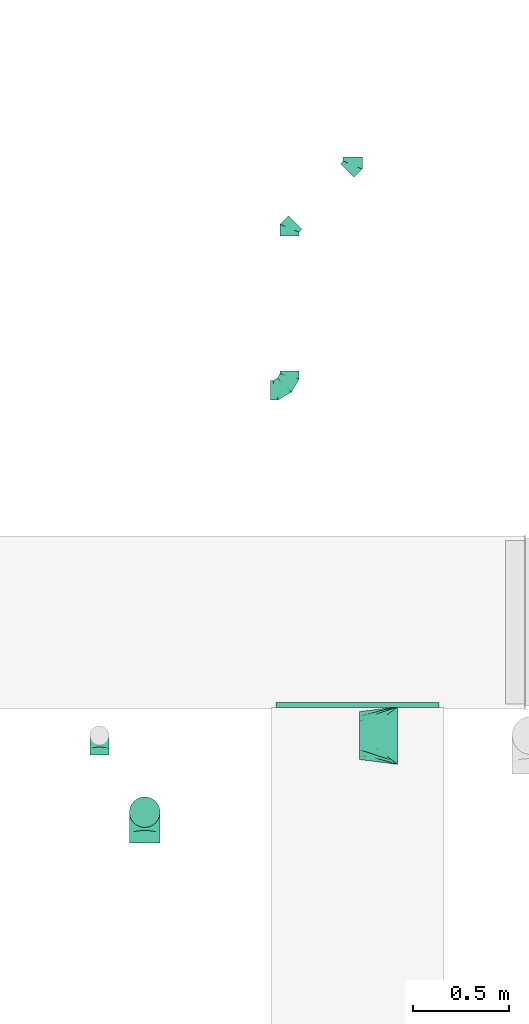
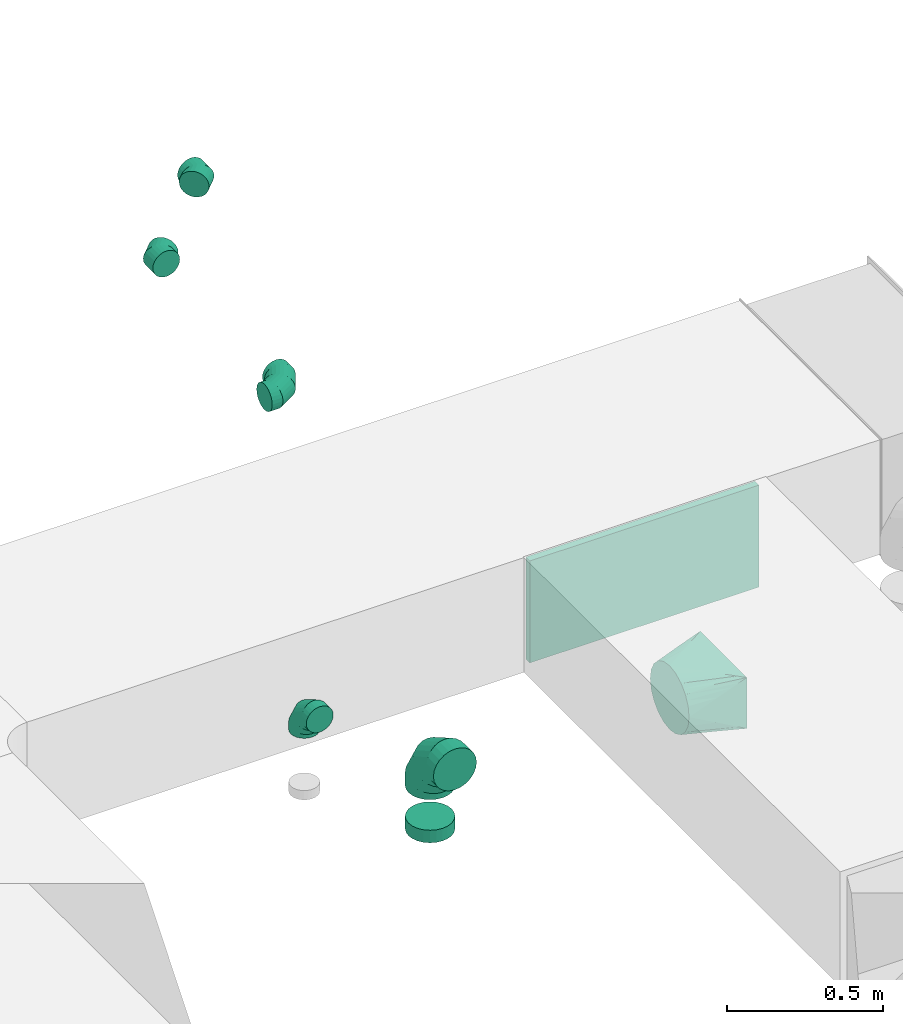
# One storey, part 23 of 62: 8 flow fittings.
"""IFC2X3 building model written with IfcOpenShell, lengths in millimetres."""

from ifc_helpers import new_model, entity, si_unit, converted_unit, derived_unit, direction, frame, origin, origin_2d_with_axis, place, context, subcontext, project, spatial, rectangle, extrude, faceted_brep, source, transform, mapped, material, type_object, type_shapes, element, save


model = new_model("IFC2X3")

# Units and contexts
model_context = context("Model", 3, precision=0.01, world=origin(), true_north=direction((6.12303176911189e-17, 1.0)))
body_context = subcontext(model_context, "Body", "Model", "MODEL_VIEW")
ifc_project = project(units=[si_unit("LENGTHUNIT", "METRE", prefix="MILLI"), si_unit("AREAUNIT", "SQUARE_METRE"), si_unit("VOLUMEUNIT", "CUBIC_METRE"), converted_unit("PLANEANGLEUNIT", "DEGREE", entity("IfcRatioMeasure", 0.0174532925199433), si_unit("PLANEANGLEUNIT", "RADIAN"), dimensions=[0, 0, 0, 0, 0, 0, 0]), si_unit("MASSUNIT", "GRAM", prefix="KILO"), derived_unit("MASSDENSITYUNIT", [(si_unit("MASSUNIT", "GRAM", prefix="KILO"), 1), (si_unit("LENGTHUNIT", "METRE"), -3)]), derived_unit("MOMENTOFINERTIAUNIT", [(si_unit("LENGTHUNIT", "METRE"), 4)]), si_unit("TIMEUNIT", "SECOND"), si_unit("FREQUENCYUNIT", "HERTZ"), si_unit("THERMODYNAMICTEMPERATUREUNIT", "DEGREE_CELSIUS"), derived_unit("THERMALTRANSMITTANCEUNIT", [(si_unit("MASSUNIT", "GRAM", prefix="KILO"), 1), (si_unit("THERMODYNAMICTEMPERATUREUNIT", "KELVIN"), -1), (si_unit("TIMEUNIT", "SECOND"), -3)]), derived_unit("VOLUMETRICFLOWRATEUNIT", [(si_unit("LENGTHUNIT", "METRE"), 3), (si_unit("TIMEUNIT", "SECOND"), -1)]), derived_unit("MASSFLOWRATEUNIT", [(si_unit("MASSUNIT", "GRAM", prefix="KILO"), 1), (si_unit("TIMEUNIT", "SECOND"), -1)]), derived_unit("ROTATIONALFREQUENCYUNIT", [(si_unit("TIMEUNIT", "SECOND"), -1)]), si_unit("ELECTRICCURRENTUNIT", "AMPERE"), si_unit("ELECTRICVOLTAGEUNIT", "VOLT"), si_unit("POWERUNIT", "WATT"), si_unit("FORCEUNIT", "NEWTON", prefix="KILO"), si_unit("ILLUMINANCEUNIT", "LUX"), si_unit("LUMINOUSFLUXUNIT", "LUMEN"), si_unit("LUMINOUSINTENSITYUNIT", "CANDELA"), derived_unit("USERDEFINED", [(si_unit("MASSUNIT", "GRAM", prefix="KILO"), -1), (si_unit("LENGTHUNIT", "METRE"), -2), (si_unit("TIMEUNIT", "SECOND"), 3), (si_unit("LUMINOUSFLUXUNIT", "LUMEN"), 1)]), derived_unit("LINEARVELOCITYUNIT", [(si_unit("LENGTHUNIT", "METRE"), 1), (si_unit("TIMEUNIT", "SECOND"), -1)]), si_unit("PRESSUREUNIT", "PASCAL"), derived_unit("USERDEFINED", [(si_unit("LENGTHUNIT", "METRE"), -2), (si_unit("MASSUNIT", "GRAM", prefix="KILO"), 1), (si_unit("TIMEUNIT", "SECOND"), -2)]), derived_unit("LINEARFORCEUNIT", [(si_unit("MASSUNIT", "GRAM", prefix="KILO"), 1), (si_unit("LENGTHUNIT", "METRE"), 1), (si_unit("TIMEUNIT", "SECOND"), -2), (si_unit("LENGTHUNIT", "METRE"), -1)]), derived_unit("PLANARFORCEUNIT", [(si_unit("MASSUNIT", "GRAM", prefix="KILO"), 1), (si_unit("LENGTHUNIT", "METRE"), 1), (si_unit("TIMEUNIT", "SECOND"), -2), (si_unit("LENGTHUNIT", "METRE"), -2)])], contexts=[model_context])

# Site, building, storey
site_placement = place(None, origin())
site = spatial("IfcSite", under=ifc_project, at=site_placement, CompositionType="ELEMENT")
building_placement = place(site_placement, origin())
building = spatial("IfcBuilding", under=site, at=building_placement, CompositionType="ELEMENT")
storey_placement = place(building_placement, frame((0.0, 0.0, 24000.0)))
storey = spatial("IfcBuildingStorey", under=building, at=storey_placement, CompositionType="ELEMENT", Elevation=24000.0)

# Flow fittings
ifc_material = material()
duct_fitting_type_1 = type_object("IfcDuctFittingType", PredefinedType="NOTDEFINED", material=ifc_material)
shared_shape_1 = source(origin(), body_context, "Body", "SweptSolid", [
    extrude(rectangle(XDim=26.0960000000013, YDim=850.0, at=origin_2d_with_axis()), frame((6.95, 0.0, -200.0)), (0.0, 0.0, 1.0), 400.0),
])
type_shapes(duct_fitting_type_1, [shared_shape_1])
flow_fitting_1_placement = place(storey_placement, frame((30224.65, 9489.97, 3550.0), z_axis=(0.0, 0.0, -1.0), x_axis=(0.0, -1.0, 0.0)))
element("IfcFlowFitting", 1, at=flow_fitting_1_placement, inside=storey, type_object=duct_fitting_type_1, material=ifc_material, context=body_context, shape_type="MappedRepresentation", body=[
    mapped(shared_shape_1, transform((0.0, 0.0, 0.0), scale=1.0)),
])
duct_fitting_type_2 = type_object("IfcDuctFittingType", PredefinedType="NOTDEFINED", material=ifc_material)
shared_shape_2 = source(origin(), body_context, "Body", "Brep", [
    faceted_brep([(-160.0, 0.0, -80.0), (-160.0, -20.71, -77.27), (-160.0, -40.0, -69.28), (-160.0, -56.57, -56.57), (-160.0, -69.28, -40.0), (-160.0, -77.27, -20.71), (-160.0, -80.0, 0.0), (-160.0, -77.27, 20.71), (-160.0, -69.28, 40.0), (-160.0, -56.57, 56.57), (-160.0, -40.0, 69.28), (-160.0, -20.71, 77.27), (-160.0, 0.0, 80.0), (-160.0, 20.71, 77.27), (-160.0, 40.0, 69.28), (-160.0, 56.57, 56.57), (-160.0, 69.28, 40.0), (-160.0, 77.27, 20.71), (-160.0, 80.0, 0.0), (-160.0, 77.27, -20.71), (-160.0, 69.28, -40.0), (-160.0, 56.57, -56.57), (-160.0, 40.0, -69.28), (-160.0, 20.71, -77.27), (-122.68, 20.71, 77.27), (-127.85, 40.0, 69.28), (-117.13, 0.0, 80.0), (-132.29, 56.57, 56.57), (-137.83, 77.27, 20.71), (-138.56, 80.0, 0.0), (-135.69, 69.28, 40.0), (-135.69, 69.28, -40.0), (-132.29, 56.57, -56.57), (-137.83, 77.27, -20.71), (-122.68, 20.71, -77.27), (-117.13, 0.0, -80.0), (-127.85, 40.0, -69.28), (-111.58, -20.71, -77.27), (-106.41, -40.0, -69.28), (-101.97, -56.57, -56.57), (-98.56, -69.28, -40.0), (-96.42, -77.27, -20.71), (-95.69, -80.0, 0.0), (-96.42, -77.27, 20.71), (-98.56, -69.28, 40.0), (-101.97, -56.57, 56.57), (-106.41, -40.0, 69.28), (-111.58, -20.71, 77.27), (-58.03, 58.03, 77.27), (-72.15, 72.15, 69.28), (-42.87, 42.87, 80.0), (-84.28, 84.28, 56.57), (-93.59, 93.59, 40.0), (-99.44, 99.44, 20.71), (-101.44, 101.44, 0.0), (-99.44, 99.44, -20.71), (-93.59, 93.59, -40.0), (-84.28, 84.28, -56.57), (-58.03, 58.03, -77.27), (-42.87, 42.87, -80.0), (-72.15, 72.15, -69.28), (-27.71, 27.71, -77.27), (-13.59, 13.59, -69.28), (-1.46, 1.46, -56.57), (7.85, -7.85, -40.0), (13.7, -13.7, -20.71), (15.69, -15.69, 0.0), (13.7, -13.7, 20.71), (7.85, -7.85, 40.0), (-1.46, 1.46, 56.57), (-13.59, 13.59, 69.28), (-27.71, 27.71, 77.27), (-20.71, 122.68, 77.27), (-40.0, 127.85, 69.28), (0.0, 117.13, 80.0), (-56.57, 132.29, 56.57), (-69.28, 135.69, 40.0), (-77.27, 137.83, 20.71), (-80.0, 138.56, 0.0), (-77.27, 137.83, -20.71), (-69.28, 135.69, -40.0), (-56.57, 132.29, -56.57), (-20.71, 122.68, -77.27), (0.0, 117.13, -80.0), (-40.0, 127.85, -69.28), (20.71, 111.58, -77.27), (40.0, 106.41, -69.28), (56.57, 101.97, -56.57), (69.28, 98.56, -40.0), (77.27, 96.42, -20.71), (80.0, 95.69, 0.0), (77.27, 96.42, 20.71), (69.28, 98.56, 40.0), (56.57, 101.97, 56.57), (40.0, 106.41, 69.28), (20.71, 111.58, 77.27), (-20.71, 160.0, -77.27), (-40.0, 160.0, -69.28), (-56.57, 160.0, -56.57), (-69.28, 160.0, -40.0), (-77.27, 160.0, -20.71), (-80.0, 160.0, 0.0), (-77.27, 160.0, 20.71), (-69.28, 160.0, 40.0), (-56.57, 160.0, 56.57), (-40.0, 160.0, 69.28), (-20.71, 160.0, 77.27), (0.0, 160.0, 80.0), (20.71, 160.0, 77.27), (40.0, 160.0, 69.28), (56.57, 160.0, 56.57), (69.28, 160.0, 40.0), (77.27, 160.0, 20.71), (80.0, 160.0, 0.0), (77.27, 160.0, -20.71), (69.28, 160.0, -40.0), (56.57, 160.0, -56.57), (40.0, 160.0, -69.28), (20.71, 160.0, -77.27), (0.0, 160.0, -80.0)], [[[0, 1, 2, 3, 4, 5, 6, 7, 8, 9, 10, 11, 12, 13, 14, 15, 16, 17, 18, 19, 20, 21, 22, 23]], [[24, 25, 14, 13]], [[26, 24, 13, 12]], [[14, 25, 27, 15]], [[28, 29, 18, 17]], [[30, 28, 17, 16]], [[15, 27, 30, 16]], [[20, 31, 32, 21]], [[33, 31, 20, 19]], [[18, 29, 33, 19]], [[34, 35, 0, 23]], [[36, 34, 23, 22]], [[32, 36, 22, 21]], [[1, 0, 35, 37]], [[2, 1, 37, 38]], [[3, 2, 38, 39]], [[5, 4, 40, 41]], [[6, 5, 41, 42]], [[39, 40, 4, 3]], [[6, 42, 43, 7]], [[7, 43, 44, 8]], [[8, 44, 45, 9]], [[9, 45, 46, 10]], [[10, 46, 47, 11]], [[26, 12, 11, 47]], [[48, 49, 25, 24]], [[50, 48, 24, 26]], [[27, 25, 49, 51]], [[52, 53, 28, 30]], [[51, 52, 30, 27]], [[29, 28, 53, 54]], [[55, 56, 31, 33]], [[54, 55, 33, 29]], [[32, 31, 56, 57]], [[58, 59, 35, 34]], [[60, 58, 34, 36]], [[57, 60, 36, 32]], [[37, 35, 59, 61]], [[38, 37, 61, 62]], [[39, 38, 62, 63]], [[41, 40, 64, 65]], [[42, 41, 65, 66]], [[63, 64, 40, 39]], [[43, 42, 66, 67]], [[44, 43, 67, 68]], [[68, 69, 45, 44]], [[46, 45, 69, 70]], [[47, 46, 70, 71]], [[26, 47, 71, 50]], [[72, 73, 49, 48]], [[74, 72, 48, 50]], [[51, 49, 73, 75]], [[76, 77, 53, 52]], [[75, 76, 52, 51]], [[54, 53, 77, 78]], [[79, 80, 56, 55]], [[78, 79, 55, 54]], [[57, 56, 80, 81]], [[82, 83, 59, 58]], [[84, 82, 58, 60]], [[81, 84, 60, 57]], [[61, 59, 83, 85]], [[62, 61, 85, 86]], [[63, 62, 86, 87]], [[65, 64, 88, 89]], [[66, 65, 89, 90]], [[87, 88, 64, 63]], [[67, 66, 90, 91]], [[68, 67, 91, 92]], [[92, 93, 69, 68]], [[70, 69, 93, 94]], [[71, 70, 94, 95]], [[50, 71, 95, 74]], [[96, 97, 98, 99, 100, 101, 102, 103, 104, 105, 106, 107, 108, 109, 110, 111, 112, 113, 114, 115, 116, 117, 118, 119]], [[72, 74, 107, 106]], [[73, 72, 106, 105]], [[75, 73, 105, 104]], [[77, 76, 103, 102]], [[78, 77, 102, 101]], [[75, 104, 103, 76]], [[78, 101, 100, 79]], [[79, 100, 99, 80]], [[80, 99, 98, 81]], [[84, 97, 96, 82]], [[82, 96, 119, 83]], [[84, 81, 98, 97]], [[118, 117, 86, 85]], [[119, 118, 85, 83]], [[116, 87, 86, 117]], [[88, 115, 114, 89]], [[89, 114, 113, 90]], [[115, 88, 87, 116]], [[112, 111, 92, 91]], [[113, 112, 91, 90]], [[111, 110, 93, 92]], [[95, 94, 109, 108]], [[74, 95, 108, 107]], [[110, 109, 94, 93]]]),
])
type_shapes(duct_fitting_type_2, [shared_shape_2])
flow_fitting_2_placement = place(storey_placement, frame((29114.61, 8924.98, 3600.0), z_axis=(1.0, 0.0, 0.0), x_axis=(0.0, 0.0, 1.0)))
element("IfcFlowFitting", 2, at=flow_fitting_2_placement, inside=storey, type_object=duct_fitting_type_2, material=ifc_material, context=body_context, shape_type="MappedRepresentation", body=[
    mapped(shared_shape_2, transform((0.0, 0.0, 0.0), scale=1.0)),
])
duct_fitting_type_3 = type_object("IfcDuctFittingType", PredefinedType="NOTDEFINED", material=ifc_material)
shared_shape_3 = source(origin(), body_context, "Body", "Brep", [
    faceted_brep([(-100.0, 0.0, -50.0), (-100.0, -12.94, -48.3), (-100.0, -25.0, -43.3), (-100.0, -35.36, -35.36), (-100.0, -43.3, -25.0), (-100.0, -48.3, -12.94), (-100.0, -50.0, 0.0), (-100.0, -48.3, 12.94), (-100.0, -43.3, 25.0), (-100.0, -35.36, 35.36), (-100.0, -25.0, 43.3), (-100.0, -12.94, 48.3), (-100.0, 0.0, 50.0), (-100.0, 12.94, 48.3), (-100.0, 25.0, 43.3), (-100.0, 35.36, 35.36), (-100.0, 43.3, 25.0), (-100.0, 48.3, 12.94), (-100.0, 50.0, 0.0), (-100.0, 48.3, -12.94), (-100.0, 43.3, -25.0), (-100.0, 35.36, -35.36), (-100.0, 25.0, -43.3), (-100.0, 12.94, -48.3), (-76.67, 12.94, 48.3), (-79.9, 25.0, 43.3), (-73.21, 0.0, 50.0), (-82.68, 35.36, 35.36), (-86.15, 48.3, 12.94), (-86.6, 50.0, 0.0), (-84.81, 43.3, 25.0), (-84.81, 43.3, -25.0), (-82.68, 35.36, -35.36), (-86.15, 48.3, -12.94), (-76.67, 12.94, -48.3), (-73.21, 0.0, -50.0), (-79.9, 25.0, -43.3), (-69.74, -12.94, -48.3), (-66.51, -25.0, -43.3), (-63.73, -35.36, -35.36), (-61.6, -43.3, -25.0), (-60.26, -48.3, -12.94), (-59.81, -50.0, 0.0), (-60.26, -48.3, 12.94), (-61.6, -43.3, 25.0), (-63.73, -35.36, 35.36), (-66.51, -25.0, 43.3), (-69.74, -12.94, 48.3), (-36.27, 36.27, 48.3), (-45.1, 45.1, 43.3), (-26.79, 26.79, 50.0), (-52.68, 52.68, 35.36), (-58.49, 58.49, 25.0), (-62.15, 62.15, 12.94), (-63.4, 63.4, 0.0), (-62.15, 62.15, -12.94), (-58.49, 58.49, -25.0), (-52.68, 52.68, -35.36), (-36.27, 36.27, -48.3), (-26.79, 26.79, -50.0), (-45.1, 45.1, -43.3), (-17.32, 17.32, -48.3), (-8.49, 8.49, -43.3), (-0.91, 0.91, -35.36), (4.9, -4.9, -25.0), (8.56, -8.56, -12.94), (9.81, -9.81, 0.0), (8.56, -8.56, 12.94), (4.9, -4.9, 25.0), (-0.91, 0.91, 35.36), (-8.49, 8.49, 43.3), (-17.32, 17.32, 48.3), (-12.94, 76.67, 48.3), (-25.0, 79.9, 43.3), (0.0, 73.21, 50.0), (-35.36, 82.68, 35.36), (-43.3, 84.81, 25.0), (-48.3, 86.15, 12.94), (-50.0, 86.6, 0.0), (-48.3, 86.15, -12.94), (-43.3, 84.81, -25.0), (-35.36, 82.68, -35.36), (-12.94, 76.67, -48.3), (0.0, 73.21, -50.0), (-25.0, 79.9, -43.3), (12.94, 69.74, -48.3), (25.0, 66.51, -43.3), (35.36, 63.73, -35.36), (43.3, 61.6, -25.0), (48.3, 60.26, -12.94), (50.0, 59.81, 0.0), (48.3, 60.26, 12.94), (43.3, 61.6, 25.0), (35.36, 63.73, 35.36), (25.0, 66.51, 43.3), (12.94, 69.74, 48.3), (-12.94, 100.0, -48.3), (-25.0, 100.0, -43.3), (-35.36, 100.0, -35.36), (-43.3, 100.0, -25.0), (-48.3, 100.0, -12.94), (-50.0, 100.0, 0.0), (-48.3, 100.0, 12.94), (-43.3, 100.0, 25.0), (-35.36, 100.0, 35.36), (-25.0, 100.0, 43.3), (-12.94, 100.0, 48.3), (0.0, 100.0, 50.0), (12.94, 100.0, 48.3), (25.0, 100.0, 43.3), (35.36, 100.0, 35.36), (43.3, 100.0, 25.0), (48.3, 100.0, 12.94), (50.0, 100.0, 0.0), (48.3, 100.0, -12.94), (43.3, 100.0, -25.0), (35.36, 100.0, -35.36), (25.0, 100.0, -43.3), (12.94, 100.0, -48.3), (0.0, 100.0, -50.0)], [[[0, 1, 2, 3, 4, 5, 6, 7, 8, 9, 10, 11, 12, 13, 14, 15, 16, 17, 18, 19, 20, 21, 22, 23]], [[24, 25, 14, 13]], [[26, 24, 13, 12]], [[14, 25, 27, 15]], [[28, 29, 18, 17]], [[30, 28, 17, 16]], [[15, 27, 30, 16]], [[20, 31, 32, 21]], [[33, 31, 20, 19]], [[18, 29, 33, 19]], [[34, 35, 0, 23]], [[36, 34, 23, 22]], [[32, 36, 22, 21]], [[2, 1, 37, 38]], [[3, 2, 38, 39]], [[0, 35, 37, 1]], [[5, 4, 40, 41]], [[6, 5, 41, 42]], [[3, 39, 40, 4]], [[6, 42, 43, 7]], [[7, 43, 44, 8]], [[8, 44, 45, 9]], [[10, 46, 47, 11]], [[11, 47, 26, 12]], [[10, 9, 45, 46]], [[48, 49, 25, 24]], [[50, 48, 24, 26]], [[27, 25, 49, 51]], [[52, 53, 28, 30]], [[51, 52, 30, 27]], [[29, 28, 53, 54]], [[55, 56, 31, 33]], [[54, 55, 33, 29]], [[57, 32, 31, 56]], [[58, 59, 35, 34]], [[60, 58, 34, 36]], [[57, 60, 36, 32]], [[37, 35, 59, 61]], [[38, 37, 61, 62]], [[39, 38, 62, 63]], [[41, 40, 64, 65]], [[42, 41, 65, 66]], [[63, 64, 40, 39]], [[43, 42, 66, 67]], [[44, 43, 67, 68]], [[68, 69, 45, 44]], [[46, 45, 69, 70]], [[47, 46, 70, 71]], [[26, 47, 71, 50]], [[72, 73, 49, 48]], [[74, 72, 48, 50]], [[51, 49, 73, 75]], [[76, 77, 53, 52]], [[75, 76, 52, 51]], [[54, 53, 77, 78]], [[79, 80, 56, 55]], [[78, 79, 55, 54]], [[81, 57, 56, 80]], [[82, 83, 59, 58]], [[84, 82, 58, 60]], [[81, 84, 60, 57]], [[61, 59, 83, 85]], [[62, 61, 85, 86]], [[63, 62, 86, 87]], [[65, 64, 88, 89]], [[66, 65, 89, 90]], [[87, 88, 64, 63]], [[67, 66, 90, 91]], [[68, 67, 91, 92]], [[92, 93, 69, 68]], [[70, 69, 93, 94]], [[71, 70, 94, 95]], [[50, 71, 95, 74]], [[96, 97, 98, 99, 100, 101, 102, 103, 104, 105, 106, 107, 108, 109, 110, 111, 112, 113, 114, 115, 116, 117, 118, 119]], [[72, 74, 107, 106]], [[73, 72, 106, 105]], [[75, 73, 105, 104]], [[77, 76, 103, 102]], [[78, 77, 102, 101]], [[75, 104, 103, 76]], [[78, 101, 100, 79]], [[79, 100, 99, 80]], [[80, 99, 98, 81]], [[96, 119, 83, 82]], [[97, 96, 82, 84]], [[84, 81, 98, 97]], [[83, 119, 118, 85]], [[85, 118, 117, 86]], [[86, 117, 116, 87]], [[88, 115, 114, 89]], [[89, 114, 113, 90]], [[87, 116, 115, 88]], [[91, 90, 113, 112]], [[92, 91, 112, 111]], [[93, 92, 111, 110]], [[95, 94, 109, 108]], [[74, 95, 108, 107]], [[110, 109, 94, 93]]]),
])
type_shapes(duct_fitting_type_3, [shared_shape_3])
flow_fitting_3_placement = place(storey_placement, frame((29870.28, 11124.85, 3400.0)))
element("IfcFlowFitting", 3, at=flow_fitting_3_placement, inside=storey, type_object=duct_fitting_type_3, material=ifc_material, context=body_context, shape_type="MappedRepresentation", body=[
    mapped(shared_shape_3, transform((0.0, 0.0, 0.0), scale=1.0)),
])
flow_fitting_4_placement = place(storey_placement, frame((28878.42, 9324.41, 3600.0), z_axis=(1.0, 0.0, 0.0), x_axis=(0.0, 0.0, 1.0)))
element("IfcFlowFitting", 4, at=flow_fitting_4_placement, inside=storey, type_object=duct_fitting_type_3, material=ifc_material, context=body_context, shape_type="MappedRepresentation", body=[
    mapped(shared_shape_3, transform((0.0, 0.0, 0.0), scale=1.0)),
])
duct_fitting_type_4 = type_object("IfcDuctFittingType", PredefinedType="NOTDEFINED", material=ifc_material)
shared_shape_4 = source(origin(), body_context, "Body", "Brep", [
    faceted_brep([(-41.42, 0.0, -50.0), (-41.42, -12.94, -48.3), (-41.42, -25.0, -43.3), (-41.42, -35.36, -35.36), (-41.42, -43.3, -25.0), (-41.42, -48.3, -12.94), (-41.42, -50.0, 0.0), (-41.42, -48.3, 12.94), (-41.42, -43.3, 25.0), (-41.42, -35.36, 35.36), (-41.42, -25.0, 43.3), (-41.42, -12.94, 48.3), (-41.42, 0.0, 50.0), (-41.42, 12.94, 48.3), (-41.42, 25.0, 43.3), (-41.42, 35.36, 35.36), (-41.42, 43.3, 25.0), (-41.42, 48.3, 12.94), (-41.42, 50.0, 0.0), (-41.42, 48.3, -12.94), (-41.42, 43.3, -25.0), (-41.42, 35.36, -35.36), (-41.42, 25.0, -43.3), (-41.42, 12.94, -48.3), (-5.36, 12.94, 48.3), (-10.36, 25.0, 43.3), (0.0, 0.0, 50.0), (-14.64, 35.36, 35.36), (-20.0, 48.3, 12.94), (-20.71, 50.0, 0.0), (-17.94, 43.3, 25.0), (-17.94, 43.3, -25.0), (-14.64, 35.36, -35.36), (-20.0, 48.3, -12.94), (-5.36, 12.94, -48.3), (0.0, 0.0, -50.0), (-10.36, 25.0, -43.3), (5.36, -12.94, -48.3), (10.36, -25.0, -43.3), (14.64, -35.36, -35.36), (17.94, -43.3, -25.0), (20.0, -48.3, -12.94), (20.71, -50.0, 0.0), (20.0, -48.3, 12.94), (17.94, -43.3, 25.0), (14.64, -35.36, 35.36), (10.36, -25.0, 43.3), (5.36, -12.94, 48.3), (29.29, 29.29, 50.0), (20.14, 38.44, 48.3), (11.61, 46.97, 43.3), (4.29, 54.29, 35.36), (-1.33, 59.91, 25.0), (-4.86, 63.44, 12.94), (-6.07, 64.64, 0.0), (-4.86, 63.44, -12.94), (-1.33, 59.91, -25.0), (4.29, 54.29, -35.36), (11.61, 46.97, -43.3), (20.14, 38.44, -48.3), (29.29, 29.29, -50.0), (38.44, 20.14, -48.3), (46.97, 11.61, -43.3), (54.29, 4.29, -35.36), (59.91, -1.33, -25.0), (63.44, -4.86, -12.94), (64.64, -6.07, 0.0), (63.44, -4.86, 12.94), (59.91, -1.33, 25.0), (54.29, 4.29, 35.36), (46.97, 11.61, 43.3), (38.44, 20.14, 48.3)], [[[0, 1, 2, 3, 4, 5, 6, 7, 8, 9, 10, 11, 12, 13, 14, 15, 16, 17, 18, 19, 20, 21, 22, 23]], [[24, 25, 14, 13]], [[26, 24, 13, 12]], [[14, 25, 27, 15]], [[28, 29, 18, 17]], [[30, 28, 17, 16]], [[16, 15, 27, 30]], [[20, 31, 32, 21]], [[33, 31, 20, 19]], [[18, 29, 33, 19]], [[34, 35, 0, 23]], [[36, 34, 23, 22]], [[32, 36, 22, 21]], [[1, 0, 35, 37]], [[2, 1, 37, 38]], [[38, 39, 3, 2]], [[5, 4, 40, 41]], [[6, 5, 41, 42]], [[39, 40, 4, 3]], [[6, 42, 43, 7]], [[7, 43, 44, 8]], [[8, 44, 45, 9]], [[9, 45, 46, 10]], [[10, 46, 47, 11]], [[26, 12, 11, 47]], [[24, 26, 48, 49]], [[25, 24, 49, 50]], [[27, 25, 50, 51]], [[28, 30, 52, 53]], [[29, 28, 53, 54]], [[27, 51, 52, 30]], [[29, 54, 55, 33]], [[33, 55, 56, 31]], [[31, 56, 57, 32]], [[36, 58, 59, 34]], [[34, 59, 60, 35]], [[36, 32, 57, 58]], [[61, 62, 38, 37]], [[60, 61, 37, 35]], [[63, 39, 38, 62]], [[40, 64, 65, 41]], [[41, 65, 66, 42]], [[64, 40, 39, 63]], [[43, 42, 66, 67]], [[44, 43, 67, 68]], [[68, 69, 45, 44]], [[47, 46, 70, 71]], [[26, 47, 71, 48]], [[69, 70, 46, 45]], [[59, 58, 57, 56, 55, 54, 53, 52, 51, 50, 49, 48, 71, 70, 69, 68, 67, 66, 65, 64, 63, 62, 61, 60]]]),
])
type_shapes(duct_fitting_type_4, [shared_shape_4])
for number, where, z_axis, x_axis in (
    (5, (30199.69, 12299.26, 3400.0), (0.0, 0.0, 1.0), (0.70710678118655, 0.707106781186545, 0.0)),
    (6, (29870.28, 11969.85, 3400.0), (0.0, 0.0, 1.0), (-0.707106781186562, -0.707106781186533, 0.0)),
):
    element("IfcFlowFitting", number, at=place(storey_placement, frame(where, z_axis=z_axis, x_axis=x_axis)), inside=storey, type_object=duct_fitting_type_4, material=ifc_material, context=body_context, shape_type="MappedRepresentation", body=[
        mapped(shared_shape_4, transform((0.0, 0.0, 0.0), scale=1.0)),
    ])
duct_fitting_type_5 = type_object("IfcDuctFittingType", PredefinedType="NOTDEFINED", material=ifc_material)
shared_shape_5 = source(origin(), body_context, "Body", "Brep", [
    faceted_brep([(200.0, 73.47, 101.13), (200.0, 56.05, 110.0), (200.0, 38.63, 118.88), (200.0, 23.84, 121.22), (200.0, 11.92, 123.11), (200.0, 5.96, 124.06), (200.0, 0.0, 125.0), (200.0, -5.96, 124.06), (200.0, -11.92, 123.11), (200.0, -23.84, 121.22), (200.0, -38.63, 118.88), (200.0, -56.05, 110.0), (200.0, -73.47, 101.13), (200.0, -87.3, 87.3), (200.0, -101.13, 73.47), (200.0, -110.0, 56.05), (200.0, -118.88, 38.63), (200.0, -121.22, 23.84), (200.0, -123.11, 11.92), (200.0, -124.06, 5.96), (200.0, -125.0, 0.0), (200.0, -124.06, -5.96), (200.0, -123.11, -11.92), (200.0, -121.22, -23.84), (200.0, -118.88, -38.63), (200.0, -110.0, -56.05), (200.0, -101.13, -73.47), (200.0, -87.3, -87.3), (200.0, -73.47, -101.13), (200.0, -56.05, -110.0), (200.0, -38.63, -118.88), (200.0, -23.84, -121.22), (200.0, -11.92, -123.11), (200.0, -5.96, -124.06), (200.0, 0.0, -125.0), (200.0, 5.96, -124.06), (200.0, 11.92, -123.11), (200.0, 23.84, -121.22), (200.0, 38.63, -118.88), (200.0, 56.05, -110.0), (200.0, 73.47, -101.13), (200.0, 87.3, -87.3), (200.0, 101.13, -73.47), (200.0, 110.0, -56.05), (200.0, 118.88, -38.63), (200.0, 121.22, -23.84), (200.0, 123.11, -11.92), (200.0, 124.06, -5.96), (200.0, 125.0, 0.0), (200.0, 124.06, 5.96), (200.0, 123.11, 11.92), (200.0, 121.22, 23.84), (200.0, 118.88, 38.63), (200.0, 110.0, 56.05), (200.0, 101.13, 73.47), (200.0, 87.3, 87.3), (0.0, -150.0, 100.0), (0.0, 150.0, 100.0), (0.0, 150.0, -100.0), (0.0, -150.0, -100.0), (104.11, -71.91, 113.01), (100.0, -116.44, 96.79), (26.03, -130.48, 103.25), (78.09, -91.44, 109.76), (52.06, -110.96, 106.51), (188.01, -8.99, 123.5), (176.03, -17.98, 122.0), (152.06, -35.96, 119.01), (128.09, -53.94, 116.01), (52.06, -143.49, 73.97), (78.09, -140.24, 60.96), (104.11, -136.99, 47.94), (128.09, -133.99, 35.96), (152.06, -130.99, 23.97), (176.03, -128.0, 11.99), (188.01, -126.5, 5.99), (26.03, -146.75, 86.99), (26.03, -146.75, -86.99), (52.06, -143.49, -73.97), (78.09, -140.24, -60.96), (104.11, -136.99, -47.94), (128.09, -133.99, -35.96), (152.06, -130.99, -23.97), (176.03, -128.0, -11.99), (188.01, -126.5, -5.99), (100.0, -121.79, -91.44), (52.06, -110.96, -106.51), (78.09, -91.44, -109.76), (104.11, -71.91, -113.01), (128.09, -53.94, -116.01), (152.06, -35.96, -119.01), (176.03, -17.98, -122.0), (188.01, -8.99, -123.5), (26.03, -130.48, -103.25), (26.03, 130.48, -103.25), (52.06, 110.96, -106.51), (78.09, 91.44, -109.76), (104.11, 71.91, -113.01), (128.09, 53.94, -116.01), (152.06, 35.96, -119.01), (176.03, 17.98, -122.0), (188.01, 8.99, -123.5), (100.0, 116.44, -96.79), (52.06, 143.49, -73.97), (78.09, 140.24, -60.96), (104.11, 136.99, -47.94), (128.09, 133.99, -35.96), (152.06, 130.99, -23.97), (176.03, 128.0, -11.99), (188.01, 126.5, -5.99), (26.03, 146.75, -86.99), (26.03, 146.75, 86.99), (52.06, 143.49, 73.97), (78.09, 140.24, 60.96), (104.11, 136.99, 47.94), (128.09, 133.99, 35.96), (152.06, 130.99, 23.97), (176.03, 128.0, 11.99), (188.01, 126.5, 5.99), (100.0, 121.79, 91.44), (52.06, 110.96, 106.51), (78.09, 91.44, 109.76), (104.11, 71.91, 113.01), (128.09, 53.94, 116.01), (152.06, 35.96, 119.01), (176.03, 17.98, 122.0), (188.01, 8.99, 123.5), (26.03, 130.48, 103.25)], [[[0, 1, 2, 3, 4, 5, 6, 7, 8, 9, 10, 11, 12, 13, 14, 15, 16, 17, 18, 19, 20, 21, 22, 23, 24, 25, 26, 27, 28, 29, 30, 31, 32, 33, 34, 35, 36, 37, 38, 39, 40, 41, 42, 43, 44, 45, 46, 47, 48, 49, 50, 51, 52, 53, 54, 55]], [[56, 57, 58, 59]], [[60, 11, 10]], [[56, 61, 62]], [[11, 60, 63, 64]], [[65, 66, 67, 68, 60, 10, 9, 8, 7, 6]], [[62, 61, 12]], [[15, 69, 70, 71]], [[64, 12, 11]], [[16, 71, 72, 73, 74, 75, 20, 19, 18, 17]], [[14, 76, 69]], [[71, 16, 15]], [[61, 76, 13]], [[12, 64, 62]], [[76, 14, 13]], [[12, 61, 13]], [[61, 56, 76]], [[69, 15, 14]], [[75, 74, 73, 72, 71, 70, 69, 76, 56, 59, 77, 78, 79, 80, 81, 82, 83, 84, 20]], [[80, 25, 24]], [[59, 85, 77]], [[25, 80, 79, 78]], [[84, 83, 82, 81, 80, 24, 23, 22, 21, 20]], [[77, 85, 26]], [[29, 86, 87, 88]], [[78, 26, 25]], [[30, 88, 89, 90, 91, 92, 34, 33, 32, 31]], [[28, 93, 86]], [[88, 30, 29]], [[85, 93, 27]], [[26, 78, 77]], [[93, 28, 27]], [[26, 85, 27]], [[85, 59, 93]], [[86, 29, 28]], [[92, 91, 90, 89, 88, 87, 86, 93, 59, 58, 94, 95, 96, 97, 98, 99, 100, 101, 34]], [[97, 39, 38]], [[58, 102, 94]], [[39, 97, 96, 95]], [[101, 100, 99, 98, 97, 38, 37, 36, 35, 34]], [[94, 102, 40]], [[43, 103, 104, 105]], [[95, 40, 39]], [[44, 105, 106, 107, 108, 109, 48, 47, 46, 45]], [[42, 110, 103]], [[105, 44, 43]], [[102, 110, 41]], [[40, 95, 94]], [[110, 42, 41]], [[40, 102, 41]], [[102, 58, 110]], [[103, 43, 42]], [[58, 57, 111, 112, 113, 114, 115, 116, 117, 118, 48, 109, 108, 107, 106, 105, 104, 103, 110]], [[114, 53, 52]], [[57, 119, 111]], [[53, 114, 113, 112]], [[118, 117, 116, 115, 114, 52, 51, 50, 49, 48]], [[111, 119, 54]], [[1, 120, 121, 122]], [[112, 54, 53]], [[2, 122, 123, 124, 125, 126, 6, 5, 4, 3]], [[0, 127, 120]], [[122, 2, 1]], [[119, 127, 55]], [[54, 112, 111]], [[127, 0, 55]], [[54, 119, 55]], [[119, 57, 127]], [[120, 1, 0]], [[57, 56, 62, 64, 63, 60, 68, 67, 66, 65, 6, 126, 125, 124, 123, 122, 121, 120, 127]]]),
])
type_shapes(duct_fitting_type_5, [shared_shape_5])
flow_fitting_5_placement = place(storey_placement, frame((30433.85, 9324.41, 3150.0), z_axis=(0.0, 0.0, 1.0), x_axis=(-1.0, 0.0, 0.0)))
element("IfcFlowFitting", 7, at=flow_fitting_5_placement, inside=storey, type_object=duct_fitting_type_5, material=ifc_material, context=body_context, shape_type="MappedRepresentation", body=[
    mapped(shared_shape_5, transform((0.0, 0.0, 0.0), scale=1.0)),
])
duct_fitting_type_6 = type_object("IfcDuctFittingType", PredefinedType="NOTDEFINED", material=ifc_material)
shared_shape_6 = source(origin(), body_context, "Body", "Brep", [
    faceted_brep([(20.0, 0.0, -80.0), (20.0, 20.71, -77.27), (20.0, 40.0, -69.28), (20.0, 56.57, -56.57), (20.0, 69.28, -40.0), (20.0, 77.27, -20.71), (20.0, 80.0, 0.0), (20.0, 77.27, 20.71), (20.0, 69.28, 40.0), (20.0, 56.57, 56.57), (20.0, 40.0, 69.28), (20.0, 20.71, 77.27), (20.0, 0.0, 80.0), (20.0, -20.71, 77.27), (20.0, -40.0, 69.28), (20.0, -56.57, 56.57), (20.0, -69.28, 40.0), (20.0, -77.27, 20.71), (20.0, -80.0, 0.0), (20.0, -77.27, -20.71), (20.0, -69.28, -40.0), (20.0, -56.57, -56.57), (20.0, -40.0, -69.28), (20.0, -20.71, -77.27), (0.0, 0.0, 80.0), (-29.21, 0.0, 80.0), (-29.21, -20.71, 77.27), (0.0, -20.71, 77.27), (-29.21, -40.0, 69.28), (0.0, -40.0, 69.28), (0.0, -56.57, 56.57), (-29.21, -56.57, 56.57), (0.0, -69.28, 40.0), (-29.21, -69.28, 40.0), (-29.21, -77.27, 20.71), (0.0, -77.27, 20.71), (-29.21, -80.0, 0.0), (0.0, -80.0, 0.0), (-29.21, -77.27, -20.71), (0.0, -77.27, -20.71), (-29.21, -69.28, -40.0), (0.0, -69.28, -40.0), (0.0, -56.57, -56.57), (-29.21, -56.57, -56.57), (0.0, -40.0, -69.28), (-29.21, -40.0, -69.28), (-29.21, -20.71, -77.27), (0.0, -20.71, -77.27), (-29.21, 0.0, -80.0), (0.0, 0.0, -80.0), (-29.21, 20.71, -77.27), (0.0, 20.71, -77.27), (-29.21, 40.0, -69.28), (0.0, 40.0, -69.28), (0.0, 56.57, -56.57), (-29.21, 56.57, -56.57), (0.0, 69.28, -40.0), (-29.21, 69.28, -40.0), (-29.21, 77.27, -20.71), (0.0, 77.27, -20.71), (-29.21, 80.0, 0.0), (0.0, 80.0, 0.0), (-29.21, 77.27, 20.71), (0.0, 77.27, 20.71), (-29.21, 69.28, 40.0), (0.0, 69.28, 40.0), (0.0, 56.57, 56.57), (-29.21, 56.57, 56.57), (0.0, 40.0, 69.28), (-29.21, 40.0, 69.28), (-29.21, 20.71, 77.27), (0.0, 20.71, 77.27)], [[[0, 1, 2, 3, 4, 5, 6, 7, 8, 9, 10, 11, 12, 13, 14, 15, 16, 17, 18, 19, 20, 21, 22, 23]], [[13, 12, 24, 25, 26, 27]], [[14, 13, 27, 26, 28, 29]], [[30, 15, 14, 29, 28, 31]], [[17, 16, 32, 33, 34, 35]], [[18, 17, 35, 34, 36, 37]], [[32, 16, 15, 30, 31, 33]], [[19, 18, 37, 36, 38, 39]], [[20, 19, 39, 38, 40, 41]], [[42, 21, 20, 41, 40, 43]], [[23, 22, 44, 45, 46, 47]], [[0, 23, 47, 46, 48, 49]], [[44, 22, 21, 42, 43, 45]], [[1, 0, 49, 48, 50, 51]], [[2, 1, 51, 50, 52, 53]], [[54, 3, 2, 53, 52, 55]], [[5, 4, 56, 57, 58, 59]], [[6, 5, 59, 58, 60, 61]], [[56, 4, 3, 54, 55, 57]], [[7, 6, 61, 60, 62, 63]], [[8, 7, 63, 62, 64, 65]], [[66, 9, 8, 65, 64, 67]], [[11, 10, 68, 69, 70, 71]], [[12, 11, 71, 70, 25, 24]], [[68, 10, 9, 66, 67, 69]], [[46, 45, 43, 40, 38, 36, 34, 33, 31, 28, 26, 25, 70, 69, 67, 64, 62, 60, 58, 57, 55, 52, 50, 48]]]),
])
type_shapes(duct_fitting_type_6, [shared_shape_6])
flow_fitting_6_placement = place(storey_placement, frame((29114.61, 8924.98, 3300.0), z_axis=(0.0, 1.0, 0.0), x_axis=(0.0, 0.0, 1.0)))
element("IfcFlowFitting", 8, at=flow_fitting_6_placement, inside=storey, type_object=duct_fitting_type_6, material=ifc_material, context=body_context, shape_type="MappedRepresentation", body=[
    mapped(shared_shape_6, transform((0.0, 0.0, 0.0), scale=1.0)),
])

save(model, "model.ifc")
